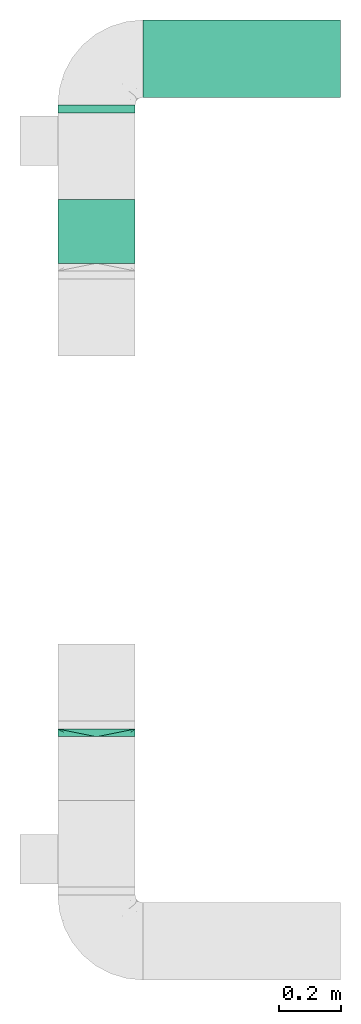
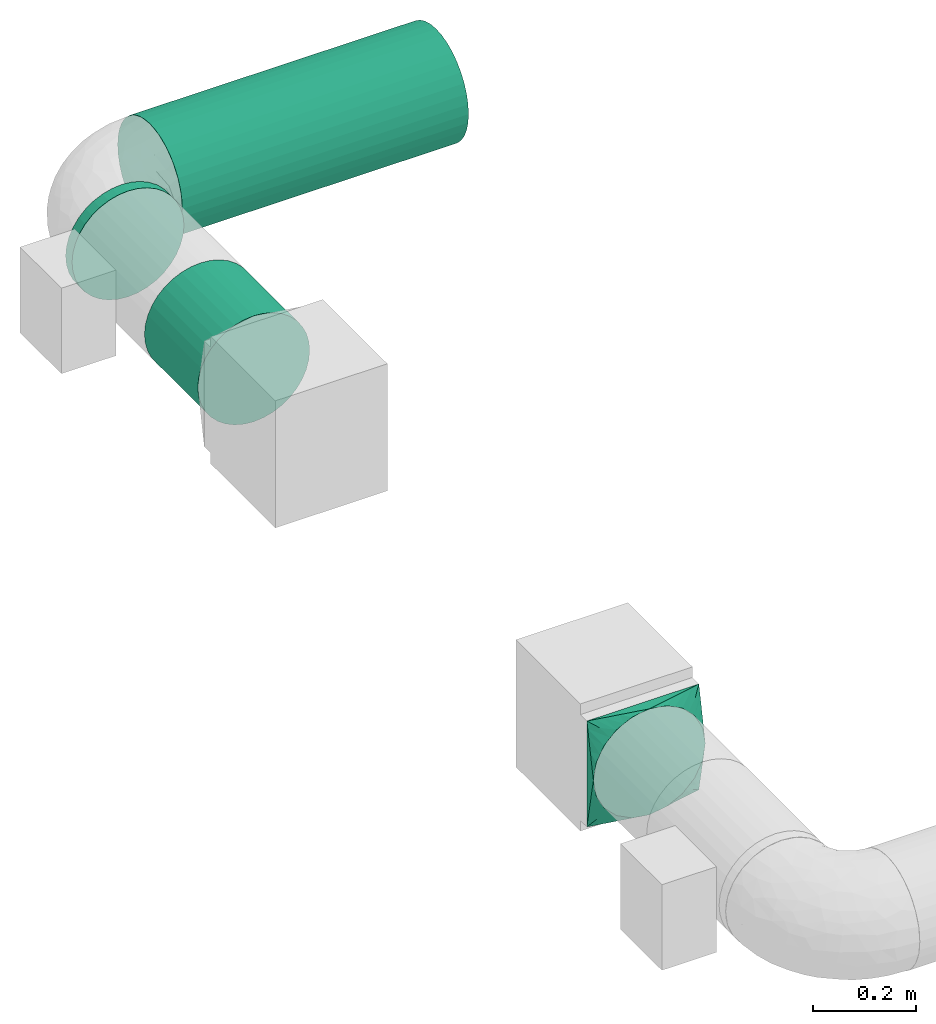
# One storey, part 2 of 4: 3 flow segments, 1 flow fitting.
"""IFC2X3 building model written with IfcOpenShell, lengths in millimetres."""

from ifc_helpers import new_model, entity, si_unit, converted_unit, derived_unit, direction, frame, origin, origin_2d_with_axis, place, context, subcontext, project, spatial, circle, extrude, faceted_brep, source, transform, mapped, material, type_object, type_shapes, element, save


model = new_model("IFC2X3")

# Units and contexts
model_context = context("Model", 3, precision=0.01, world=origin(), true_north=direction((6.12303176911189e-17, 1.0)))
body_context = subcontext(model_context, "Body", "Model", "MODEL_VIEW")
ifc_project = project(units=[si_unit("LENGTHUNIT", "METRE", prefix="MILLI"), si_unit("AREAUNIT", "SQUARE_METRE"), si_unit("VOLUMEUNIT", "CUBIC_METRE"), converted_unit("PLANEANGLEUNIT", "DEGREE", entity("IfcRatioMeasure", 0.0174532925199433), si_unit("PLANEANGLEUNIT", "RADIAN"), dimensions=[0, 0, 0, 0, 0, 0, 0]), si_unit("MASSUNIT", "GRAM", prefix="KILO"), derived_unit("MASSDENSITYUNIT", [(si_unit("MASSUNIT", "GRAM", prefix="KILO"), 1), (si_unit("LENGTHUNIT", "METRE"), -3)]), si_unit("TIMEUNIT", "SECOND"), si_unit("FREQUENCYUNIT", "HERTZ"), si_unit("THERMODYNAMICTEMPERATUREUNIT", "DEGREE_CELSIUS"), derived_unit("THERMALTRANSMITTANCEUNIT", [(si_unit("MASSUNIT", "GRAM", prefix="KILO"), 1), (si_unit("THERMODYNAMICTEMPERATUREUNIT", "KELVIN"), -1), (si_unit("TIMEUNIT", "SECOND"), -3)]), derived_unit("VOLUMETRICFLOWRATEUNIT", [(si_unit("LENGTHUNIT", "METRE"), 3), (si_unit("TIMEUNIT", "SECOND"), -1)]), si_unit("ELECTRICCURRENTUNIT", "AMPERE"), si_unit("ELECTRICVOLTAGEUNIT", "VOLT"), si_unit("POWERUNIT", "WATT"), si_unit("FORCEUNIT", "NEWTON", prefix="KILO"), si_unit("ILLUMINANCEUNIT", "LUX"), si_unit("LUMINOUSFLUXUNIT", "LUMEN"), si_unit("LUMINOUSINTENSITYUNIT", "CANDELA"), derived_unit("USERDEFINED", [(si_unit("MASSUNIT", "GRAM", prefix="KILO"), -1), (si_unit("LENGTHUNIT", "METRE"), -2), (si_unit("TIMEUNIT", "SECOND"), 3), (si_unit("LUMINOUSFLUXUNIT", "LUMEN"), 1)]), derived_unit("LINEARVELOCITYUNIT", [(si_unit("LENGTHUNIT", "METRE"), 1), (si_unit("TIMEUNIT", "SECOND"), -1)]), si_unit("PRESSUREUNIT", "PASCAL"), derived_unit("USERDEFINED", [(si_unit("LENGTHUNIT", "METRE"), -2), (si_unit("MASSUNIT", "GRAM", prefix="KILO"), 1), (si_unit("TIMEUNIT", "SECOND"), -2)])], contexts=[model_context])

# Site, building, storey
site_placement = place(None, origin())
site = spatial("IfcSite", under=ifc_project, at=site_placement, CompositionType="ELEMENT")
building_placement = place(site_placement, origin())
building = spatial("IfcBuilding", under=site, at=building_placement, CompositionType="ELEMENT")
storey_placement = place(building_placement, frame((0.0, 0.0, 8000.0)))
storey = spatial("IfcBuildingStorey", under=building, at=storey_placement, Name="02 Level", CompositionType="ELEMENT", Elevation=8000.0)

# Flow segments
duct_segment_type = type_object("IfcDuctSegmentType", Name="Round Duct:Air", PredefinedType="NOTDEFINED")
flow_segment_1_placement = place(storey_placement, frame((25345.9632723171, -67531.6128003217, 3383.40472776408)))
element("IfcFlowSegment", 1, at=flow_segment_1_placement, inside=storey, type_object=duct_segment_type, Name="Round Duct:Air", ObjectType="Round Duct:Air", context=body_context, shape_type="SweptSolid", body=[
    extrude(circle(Radius=125.0, at=origin_2d_with_axis()), frame((0.0, 126.595272235913, 126.595272235916), z_axis=(1.0, 0.0, 0.0), x_axis=(0.0, 1.0, 0.0)), (0.0, 0.0, 1.0), 639.200332511935),
])
flow_segment_2_placement = place(storey_placement, frame((25069.3680000812, -67580.0175280859, 3383.40472776408)))
element("IfcFlowSegment", 2, at=flow_segment_2_placement, inside=storey, type_object=duct_segment_type, Name="Round Duct:Air", ObjectType="Round Duct:Air", context=body_context, shape_type="SweptSolid", body=[
    extrude(circle(Radius=125.0, at=origin_2d_with_axis()), frame((126.595272235918, 0.0, 126.595272235916), z_axis=(0.0, 1.0, 0.0), x_axis=(-1.0, 0.0, 0.0)), (0.0, 0.0, 1.0), 25.0000000001243),
])
flow_segment_3_placement = place(storey_placement, frame((25069.3680000811, -68066.2395851399, 3383.40472776408)))
element("IfcFlowSegment", 3, at=flow_segment_3_placement, inside=storey, type_object=duct_segment_type, Name="Round Duct:Air", ObjectType="Round Duct:Air", context=body_context, shape_type="SweptSolid", body=[
    extrude(circle(Radius=125.0, at=origin_2d_with_axis()), frame((126.595272235918, 0.0, 126.595272235916), z_axis=(0.0, 1.0, 0.0), x_axis=(-1.0, 0.0, 0.0)), (0.0, 0.0, 1.0), 206.222057054006),
])

# Flow fitting
ifc_material = material(Name="Material_Duct")
duct_fitting_type = type_object("IfcDuctFittingType", Name="Air_Multi shape transition_Circ", PredefinedType="NOTDEFINED", material=ifc_material)
shared_shape = source(origin(), body_context, "Body", "Brep", [
    faceted_brep([(25.0, -38.627124296869, -118.882064536893), (25.0, -23.8439039196152, -121.223496622539), (25.0, -11.9219519598079, -123.111748311269), (25.0, -5.96097597990422, -124.055874155634), (25.0, 0.0, -125.0), (25.0, 5.9609759747813, -124.055874156445), (25.0, 11.9219519495628, -123.111748312892), (25.0, 23.8439038991258, -121.223496625784), (25.0, 38.6271242968683, -118.882064536893), (25.0, 56.0501404167137, -110.00459441688), (25.0, 73.4731565365591, -101.127124296868), (25.0, 87.3001404167137, -87.3001404167129), (25.0, 101.127124296868, -73.4731565365583), (25.0, 110.004594416881, -56.0501404167129), (25.0, 118.882064536894, -38.6271242968675), (25.0, 121.22349662254, -23.8439039196137), (25.0, 123.11174831127, -11.9219519598064), (25.0, 124.055874155635, -5.96097597990274), (25.0, 125.0, 0.0), (25.0, 124.055874156446, 5.96097597478117), (25.0, 123.111748312892, 11.9219519495627), (25.0, 121.223496625785, 23.8439038991257), (25.0, 118.882064536894, 38.6271242968681), (25.0, 110.004594416881, 56.0501404167135), (25.0, 101.127124296869, 73.4731565365589), (25.0, 87.300140416714, 87.3001404167136), (25.0, 73.4731565365594, 101.127124296868), (25.0, 56.050140416714, 110.004594416881), (25.0, 38.6271242968687, 118.882064536894), (25.0, 23.8439039196148, 121.22349662254), (25.0, 11.9219519598075, 123.11174831127), (25.0, 5.96097597990388, 124.055874155635), (25.0, 0.0, 125.0), (25.0, -5.96097597478126, 124.055874156446), (25.0, -11.9219519495628, 123.111748312892), (25.0, -23.8439038991258, 121.223496625785), (25.0, -38.6271242968682, 118.882064536894), (25.0, -56.0501404167136, 110.004594416881), (25.0, -73.473156536559, 101.127124296869), (25.0, -87.3001404167137, 87.3001404167139), (25.0, -101.127124296868, 73.4731565365593), (25.0, -110.004594416881, 56.0501404167139), (25.0, -118.882064536894, 38.6271242968685), (25.0, -121.22349662254, 23.8439039196147), (25.0, -123.11174831127, 11.9219519598073), (25.0, -124.055874155635, 5.96097597990369), (25.0, -125.0, 0.0), (25.0, -124.055874156446, -5.96097597478013), (25.0, -123.111748312892, -11.9219519495616), (25.0, -121.223496625785, -23.8439038991246), (25.0, -118.882064536894, -38.6271242968671), (25.0, -110.004594416882, -56.0501404167124), (25.0, -101.127124296869, -73.4731565365578), (25.0, -87.3001404167141, -87.3001404167125), (25.0, -73.4731565365595, -101.127124296867), (25.0, -56.0501404167142, -110.00459441688), (0.0, -125.0, 125.0), (0.0, 125.0, 125.0), (0.0, 125.0, -125.0), (0.0, -125.0, -125.0), (13.0142783389037, -59.9286083054818, 125.0), (12.4999999334883, -103.93826768006, 109.288032538106), (3.25356958472593, -108.732152076371, 125.0), (9.76070875417778, -76.1964562291116, 125.0), (6.50713916945186, -92.4643041527413, 125.0), (23.501784792363, -7.49107603818501, 125.0), (22.0035695847259, -14.9821520763703, 125.0), (19.0071391694519, -29.9643041527408, 125.0), (16.0107087541778, -44.9464562291113, 125.0), (6.50713897169544, -125.0, 92.464305141524), (9.76070845754317, -125.0, 76.1964577122852), (13.0142779433909, -125.0, 59.9286102830464), (16.0107084575432, -125.0, 44.9464577122848), (19.0071389716954, -125.0, 29.9643051415232), (22.0035694858477, -125.0, 14.9821525707616), (23.5017847429239, -125.0, 7.49107628538082), (3.25356948584772, -125.0, 108.732152570763), (3.25356958472593, -125.0, -108.73215207637), (6.50713916945185, -125.0, -92.4643041527404), (9.76070875417777, -125.0, -76.1964562291106), (13.0142783389037, -125.0, -59.9286083054808), (16.0107087541778, -125.0, -44.9464562291103), (19.0071391694518, -125.0, -29.9643041527397), (22.0035695847259, -125.0, -14.9821520763692), (23.501784792363, -125.0, -7.4910760381839), (12.4999999334883, -109.288032538106, -103.938267680059), (6.50713897169543, -92.4643051415237, -125.0), (9.76070845754315, -76.196457712285, -125.0), (13.0142779433909, -59.9286102830464, -125.0), (16.0107084575432, -44.9464577122849, -125.0), (19.0071389716954, -29.9643051415235, -125.0), (22.0035694858477, -14.982152570762, -125.0), (23.5017847429239, -7.49107628538127, -125.0), (3.25356948584772, -108.732152570762, -125.0), (3.25356958472593, 108.73215207637, -125.0), (6.50713916945186, 92.4643041527402, -125.0), (9.76070875417778, 76.1964562291106, -125.0), (13.0142783389037, 59.9286083054811, -125.0), (16.0107087541778, 44.9464562291108, -125.0), (19.0071391694519, 29.9643041527404, -125.0), (22.0035695847259, 14.9821520763701, -125.0), (23.501784792363, 7.49107603818496, -125.0), (12.4999999334883, 103.938267680059, -109.288032538105), (6.50713897169544, 125.0, -92.4643051415225), (9.76070845754317, 125.0, -76.1964577122838), (13.0142779433909, 125.0, -59.9286102830451), (16.0107084575432, 125.0, -44.9464577122836), (19.0071389716954, 125.0, -29.9643051415221), (22.0035694858477, 125.0, -14.9821525707606), (23.5017847429239, 125.0, -7.49107628537983), (3.25356948584772, 125.0, -108.732152570761), (3.25356958472593, 125.0, 108.732152076372), (6.50713916945185, 125.0, 92.4643041527418), (9.76070875417778, 125.0, 76.196456229112), (13.0142783389037, 125.0, 59.9286083054821), (16.0107087541778, 125.0, 44.9464562291115), (19.0071391694519, 125.0, 29.9643041527409), (22.0035695847259, 125.0, 14.9821520763703), (23.501784792363, 125.0, 7.49107603818497), (12.4999999334883, 109.288032538105, 103.93826768006), (6.50713897169544, 92.4643051415224, 125.0), (9.76070845754316, 76.1964577122839, 125.0), (13.0142779433909, 59.9286102830454, 125.0), (16.0107084575432, 44.9464577122841, 125.0), (19.0071389716954, 29.9643051415228, 125.0), (22.0035694858477, 14.9821525707615, 125.0), (23.5017847429239, 7.49107628538087, 125.0), (3.25356948584772, 108.732152570761, 125.0)], [[[0, 1, 2, 3, 4, 5, 6, 7, 8, 9, 10, 11, 12, 13, 14, 15, 16, 17, 18, 19, 20, 21, 22, 23, 24, 25, 26, 27, 28, 29, 30, 31, 32, 33, 34, 35, 36, 37, 38, 39, 40, 41, 42, 43, 44, 45, 46, 47, 48, 49, 50, 51, 52, 53, 54, 55]], [[56, 57, 58, 59]], [[60, 37, 36]], [[56, 61, 62]], [[37, 60, 63, 64]], [[65, 66, 67, 68, 60, 36, 35, 34, 33, 32]], [[62, 61, 38]], [[41, 69, 70, 71]], [[64, 38, 37]], [[42, 71, 72, 73, 74, 75, 46, 45, 44, 43]], [[40, 76, 69]], [[71, 42, 41]], [[61, 76, 39]], [[38, 64, 62]], [[76, 40, 39]], [[38, 61, 39]], [[61, 56, 76]], [[69, 41, 40]], [[56, 59, 77, 78, 79, 80, 81, 82, 83, 84, 46, 75, 74, 73, 72, 71, 70, 69, 76]], [[80, 51, 50]], [[59, 85, 77]], [[51, 80, 79, 78]], [[84, 83, 82, 81, 80, 50, 49, 48, 47, 46]], [[77, 85, 52]], [[55, 86, 87, 88]], [[78, 52, 51]], [[0, 88, 89, 90, 91, 92, 4, 3, 2, 1]], [[54, 93, 86]], [[88, 0, 55]], [[85, 93, 53]], [[52, 78, 77]], [[93, 54, 53]], [[52, 85, 53]], [[85, 59, 93]], [[86, 55, 54]], [[92, 91, 90, 89, 88, 87, 86, 93, 59, 58, 94, 95, 96, 97, 98, 99, 100, 101, 4]], [[97, 9, 8]], [[58, 102, 94]], [[9, 97, 96, 95]], [[101, 100, 99, 98, 97, 8, 7, 6, 5, 4]], [[94, 102, 10]], [[13, 103, 104, 105]], [[95, 10, 9]], [[14, 105, 106, 107, 108, 109, 18, 17, 16, 15]], [[12, 110, 103]], [[105, 14, 13]], [[102, 110, 11]], [[10, 95, 94]], [[110, 12, 11]], [[10, 102, 11]], [[102, 58, 110]], [[103, 13, 12]], [[58, 57, 111, 112, 113, 114, 115, 116, 117, 118, 18, 109, 108, 107, 106, 105, 104, 103, 110]], [[114, 23, 22]], [[57, 119, 111]], [[23, 114, 113, 112]], [[118, 117, 116, 115, 114, 22, 21, 20, 19, 18]], [[111, 119, 24]], [[27, 120, 121, 122]], [[112, 24, 23]], [[28, 122, 123, 124, 125, 126, 32, 31, 30, 29]], [[26, 127, 120]], [[122, 28, 27]], [[119, 127, 25]], [[24, 112, 111]], [[127, 26, 25]], [[24, 119, 25]], [[119, 57, 127]], [[120, 27, 26]], [[57, 56, 62, 64, 63, 60, 68, 67, 66, 65, 32, 126, 125, 124, 123, 122, 121, 120, 127]]]),
])
type_shapes(duct_fitting_type, [shared_shape])
flow_fitting_placement = place(storey_placement, frame((25195.9632723171, -69571.2395851399, 3510.0), z_axis=(0.0, 0.0, 1.0), x_axis=(0.0, -1.0, 0.0)))
element("IfcFlowFitting", 4, at=flow_fitting_placement, inside=storey, type_object=duct_fitting_type, material=ifc_material, Name="multi_shape_trans_001:Air_Multi shape transition_Circ", ObjectType="multi_shape_trans_001:Air_Multi shape transition_Circ", context=body_context, shape_type="MappedRepresentation", body=[
    mapped(shared_shape, transform((0.0, 0.0, 0.0), scale=1.0)),
])

save(model, "model.ifc")
